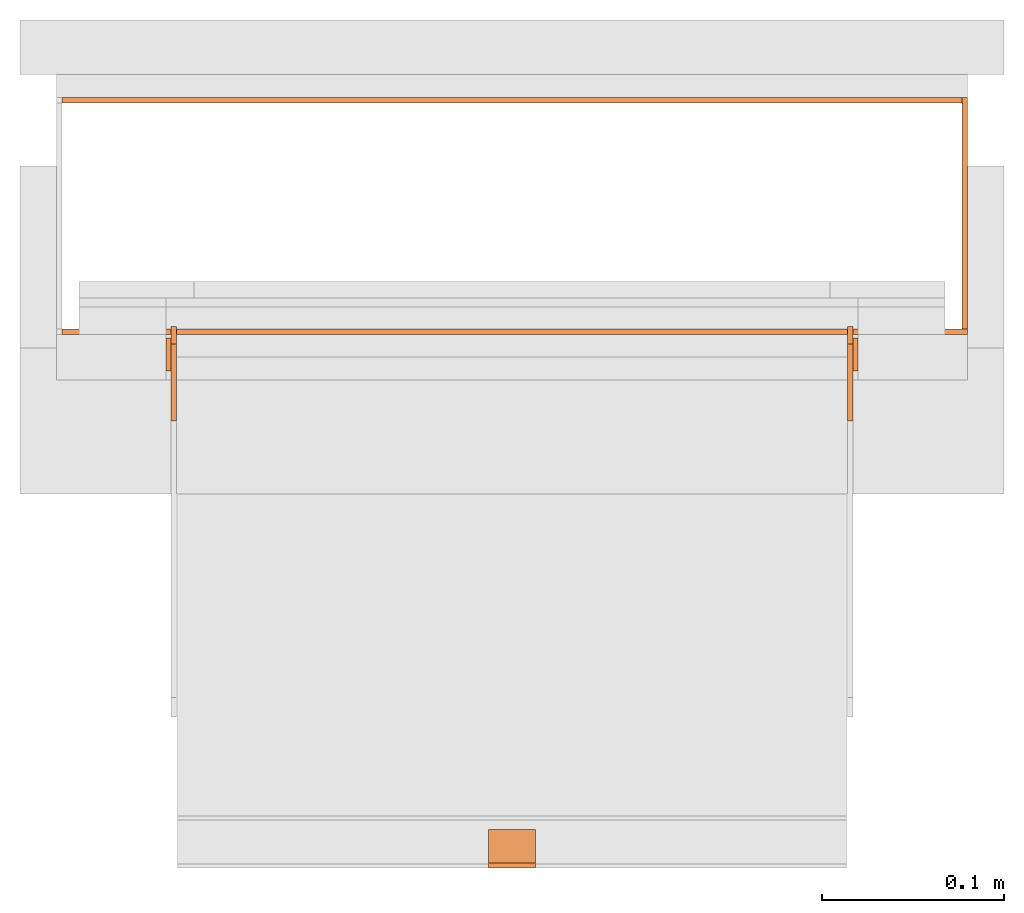
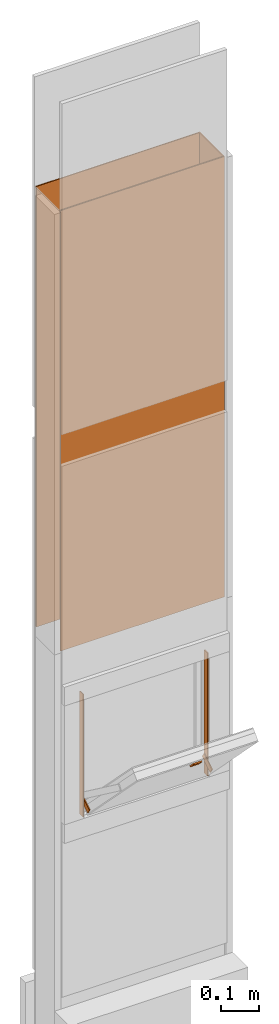
# One storey, part 2 of 3: 8 proxies.
"""IFC2X3 building model written with IfcOpenShell, lengths in metres."""

from ifc_helpers import new_model, entity, si_unit, converted_unit, derived_unit, money_unit, direction, frame, origin_with_axes, place, context, subcontext, project, spatial, polyline, outline, extrude, boolean, faceted_brep, source, transform, mapped, material, type_object, element, save


model = new_model("IFC2X3")

# Units and contexts
model_context = context("Model", 3, precision=1e-05, world=origin_with_axes(), true_north=direction((0.0, 1.0)))
plan_context = context("Plan", 3, precision=1e-05, world=origin_with_axes(), true_north=direction((0.0, 1.0)))
body_context = subcontext(model_context, "Body", "Model", "MODEL_VIEW")
ifc_project = project(units=[si_unit("LENGTHUNIT", "METRE"), si_unit("AREAUNIT", "SQUARE_METRE"), si_unit("VOLUMEUNIT", "CUBIC_METRE"), converted_unit("PLANEANGLEUNIT", "DEGREE", entity("IfcPlaneAngleMeasure", 0.0174532925199), si_unit("PLANEANGLEUNIT", "RADIAN"), dimensions=[0, 0, 0, 0, 0, 0, 0]), si_unit("SOLIDANGLEUNIT", "STERADIAN"), money_unit("CHF"), converted_unit("TIMEUNIT", "Year", entity("IfcTimeMeasure", 31556926.0), si_unit("TIMEUNIT", "SECOND"), dimensions=[0, 0, 1, 0, 0, 0, 0]), si_unit("MASSUNIT", "GRAM", prefix="KILO"), si_unit("THERMODYNAMICTEMPERATUREUNIT", "DEGREE_CELSIUS"), si_unit("LUMINOUSINTENSITYUNIT", "LUMEN"), si_unit("ENERGYUNIT", "JOULE", prefix="MEGA"), derived_unit("THERMALCONDUCTANCEUNIT", [(si_unit("POWERUNIT", "WATT"), 1), (si_unit("LENGTHUNIT", "METRE"), -1), (si_unit("THERMODYNAMICTEMPERATUREUNIT", "KELVIN"), -1)]), derived_unit("SPECIFICHEATCAPACITYUNIT", [(si_unit("ENERGYUNIT", "JOULE"), 1), (si_unit("MASSUNIT", "GRAM", prefix="KILO"), -1), (si_unit("THERMODYNAMICTEMPERATUREUNIT", "KELVIN"), -1)]), derived_unit("MASSDENSITYUNIT", [(si_unit("MASSUNIT", "GRAM", prefix="KILO"), 1), (si_unit("VOLUMEUNIT", "CUBIC_METRE"), -1)])], contexts=[model_context, plan_context])

# Site, building, storey
site_placement = place(None, origin_with_axes())
site = spatial("IfcSite", under=ifc_project, at=site_placement, CompositionType="ELEMENT")
building_placement = place(site_placement, origin_with_axes())
building = spatial("IfcBuilding", under=site, at=building_placement, CompositionType="ELEMENT")
storey_placement = place(building_placement, frame((0.0, 0.0, 2.96), z_axis=(0.0, 0.0, 1.0), x_axis=(1.0, 0.0, 0.0)))
storey = spatial("IfcBuildingStorey", under=building, at=storey_placement, Name="OG01", CompositionType="ELEMENT", Elevation=2.96)

# Proxies
ifc_material_1 = material(Name="Metall, Stahl")
building_element_proxy_type_1 = type_object("IfcBuildingElementProxyType", Name="Metall, Stahl 3", PredefinedType="NOTDEFINED")
proxy_1_placement = place(storey_placement, frame((2.05655524907, -8.09743070606, 1.15), z_axis=(0.0, 0.0, 1.0), x_axis=(-1.0, 0.0, 0.0)))
element("IfcBuildingElementProxy", 1, at=proxy_1_placement, inside=storey, type_object=building_element_proxy_type_1, material=ifc_material_1, Name="Wand-008", context=body_context, shape_type="CSG", body=[
    boolean("DIFFERENCE", boolean("DIFFERENCE", extrude(outline(polyline([(0.0, 0.0), (0.5, 0.0), (0.5, 0.003), (0.0, 0.003), (0.0, 0.0)])), origin_with_axes(), (0.0, 0.0, 1.0), 1.41), faceted_brep([(0.497, 0.003, 1.41), (0.497, 0.0, 1.41), (0.5, 0.0, 1.41), (0.5, 0.003, 1.41), (0.497, 0.0, 0.0), (0.497, 0.003, 0.0), (0.5, 0.0, 0.0), (0.5, 0.003, 0.0)], [[[0, 1, 2, 3]], [[4, 1, 0, 5]], [[1, 4, 6, 2]], [[2, 6, 7, 3]], [[5, 0, 3, 7]], [[4, 5, 7, 6]]])), faceted_brep([(0.003, 0.0, 0.0), (0.003, 0.0, 1.41), (0.0, 0.0, 1.41), (0.0, 0.0, 0.0), (0.003, 0.003, 1.41), (0.003, 0.003, 0.0), (0.0, 0.003, 1.41), (0.0, 0.003, 0.0)], [[[0, 1, 2, 3]], [[4, 1, 0, 5]], [[1, 4, 6, 2]], [[6, 7, 3, 2]], [[5, 0, 3, 7]], [[4, 5, 7, 6]]])),
])
proxy_2_placement = place(storey_placement, frame((1.55655524907, -8.22743070606, 1.15), z_axis=(0.0, 0.0, 1.0), x_axis=(1.0, 0.0, 0.0)))
element("IfcBuildingElementProxy", 2, at=proxy_2_placement, inside=storey, type_object=building_element_proxy_type_1, material=ifc_material_1, Name="Wand-006", context=body_context, shape_type="CSG", body=[
    boolean("DIFFERENCE", extrude(outline(polyline([(0.0, 0.0), (0.5, 0.0), (0.5, 0.003), (0.0, 0.003), (0.0, 0.0)])), origin_with_axes(), (0.0, 0.0, 1.0), 1.41), faceted_brep([(0.003, 0.0, 1.41), (0.003, 0.003, 1.41), (0.0, 0.003, 1.41), (0.0, 0.0, 1.41), (0.003, 0.003, 0.0), (0.003, 0.0, 0.0), (0.0, 0.003, 0.0), (0.0, 0.0, 0.0)], [[[0, 1, 2, 3]], [[4, 1, 0, 5]], [[1, 4, 6, 2]], [[2, 6, 7, 3]], [[5, 0, 3, 7]], [[4, 5, 7, 6]]])),
])
proxy_3_placement = place(storey_placement, frame((2.05655524907, -8.22743070606, 1.15), z_axis=(0.0, 0.0, 1.0), x_axis=(0.0, 1.0, 0.0)))
element("IfcBuildingElementProxy", 3, at=proxy_3_placement, inside=storey, type_object=building_element_proxy_type_1, material=ifc_material_1, Name="Wand-007", context=body_context, shape_type="CSG", body=[
    boolean("DIFFERENCE", extrude(outline(polyline([(0.0, 0.0), (0.13, 0.0), (0.13, 0.003), (0.0, 0.003), (0.0, 0.0)])), origin_with_axes(), (0.0, 0.0, 1.0), 1.41), faceted_brep([(0.003, 0.0, 0.0), (0.003, 0.0, 1.41), (0.0, 0.0, 1.41), (0.0, 0.0, 0.0), (0.003, 0.003, 1.41), (0.003, 0.003, 0.0), (0.0, 0.003, 1.41), (0.0, 0.003, 0.0)], [[[0, 1, 2, 3]], [[4, 1, 0, 5]], [[1, 4, 6, 2]], [[6, 7, 3, 2]], [[5, 0, 3, 7]], [[4, 5, 7, 6]]])),
])
ifc_material_2 = material(Name="Metall, Aluminium")
building_element_proxy_type_2 = type_object("IfcBuildingElementProxyType", Name="Metall, Aluminium", PredefinedType="NOTDEFINED")
shared_shape_1 = source(origin_with_axes(), body_context, "Body", "Brep", [
    faceted_brep([(16.1345115895, -3.59726483298, 0.726478855326), (16.1345115895, -3.60026483298, 0.726478855326), (16.1345115895, -3.60026483298, 0.776478855326), (16.1345115895, -3.59726483298, 0.776478855326), (16.1525115895, -3.60026483298, 0.726478855326), (16.1525115895, -3.59726483298, 0.726478855326), (16.1525115895, -3.60026483298, 0.776478855326), (16.1525115895, -3.59726483298, 0.776478855326)], [[[0, 1, 2, 3]], [[4, 1, 0, 5]], [[1, 4, 6, 2]], [[2, 6, 7, 3]], [[0, 3, 7, 5]], [[4, 5, 7, 6]]]),
])
for number, where, z_axis, x_axis, name in (
    (4, (5.21982008204, -16.2173099117, 14.7145311427), (0.0, -0.846133712697, -0.532970674838), (0.0, 0.532970674838, -0.846133712697), "Wand-005"),
    (5, (5.59082008204, -16.2173099117, 14.7145311427), (0.0, -0.846133712697, -0.532970674838), (0.0, 0.532970674838, -0.846133712697), "Wand-005"),
):
    element("IfcBuildingElementProxy", number, at=place(storey_placement, frame(where, z_axis=z_axis, x_axis=x_axis)), inside=storey, type_object=building_element_proxy_type_2, material=ifc_material_2, Name=name, context=body_context, shape_type="MappedRepresentation", body=[
        mapped(shared_shape_1, transform((0.0, 0.0, 0.0))),
    ])
building_element_proxy_type_3 = type_object("IfcBuildingElementProxyType", Name="Metall, Aluminium 3", PredefinedType="NOTDEFINED")
proxy_4_placement = place(storey_placement, frame((1.99655524907, -8.22943070606, 0.61), z_axis=(0.0, 0.0, 1.0), x_axis=(0.0, -1.0, 0.0)))
element("IfcBuildingElementProxy", 6, at=proxy_4_placement, inside=storey, type_object=building_element_proxy_type_3, material=ifc_material_2, Name="Wand-006", context=body_context, shape_type="SweptSolid", body=[
    extrude(outline(polyline([(0.0, -0.003), (0.018, -0.003), (0.018, 0.0), (0.0, 0.0), (0.0, -0.003)])), origin_with_axes(), (0.0, 0.0, 1.0), 0.393521144674),
])
proxy_5_placement = place(storey_placement, frame((1.61655524907, -8.22943070606, 0.61), z_axis=(0.0, 0.0, 1.0), x_axis=(0.0, -1.0, 0.0)))
element("IfcBuildingElementProxy", 7, at=proxy_5_placement, inside=storey, type_object=building_element_proxy_type_3, material=ifc_material_2, Name="Wand-006", context=body_context, shape_type="SweptSolid", body=[
    extrude(outline(polyline([(0.0, 0.0), (0.018, 0.0), (0.018, 0.003), (0.0, 0.003), (0.0, 0.0)])), origin_with_axes(), (0.0, 0.0, 1.0), 0.393521144674),
])
shared_shape_2 = source(origin_with_axes(), body_context, "Body", "Brep", [
    faceted_brep([(16.3888858635, -3.43025891523, 1.114), (16.3888858635, -3.43025891523, 1.14), (16.3888858635, -3.40425891523, 1.14), (16.3888858635, -3.40425891523, 1.114), (16.3928858635, -3.43025891523, 1.114), (16.3928858635, -3.43025891523, 1.14), (16.3928858635, -3.40825891523, 1.14), (16.3928858635, -3.40425891523, 1.14), (16.3928858635, -3.40425891523, 1.114), (16.3928858635, -3.40825891523, 1.114)], [[[0, 1, 2, 3]], [[1, 0, 4]], [[2, 1, 5, 6, 7]], [[3, 2, 7, 8]], [[0, 3, 8, 9, 4]], [[1, 4, 5]], [[6, 5, 4]], [[6, 9, 8, 7]], [[9, 6, 4]]]),
])
proxy_6_placement = place(storey_placement, frame((5.2238141643, 3.98081117247, 11.5470677443), z_axis=(0.0, -0.700249431637, 0.713898265506), x_axis=(0.0, -0.713898265506, -0.700249431637)))
element("IfcBuildingElementProxy", 8, at=proxy_6_placement, inside=storey, type_object=building_element_proxy_type_2, material=ifc_material_2, Name="Wand-007", context=body_context, shape_type="MappedRepresentation", body=[
    mapped(shared_shape_2, transform((0.0, 0.0, 0.0))),
])

save(model, "model.ifc")
